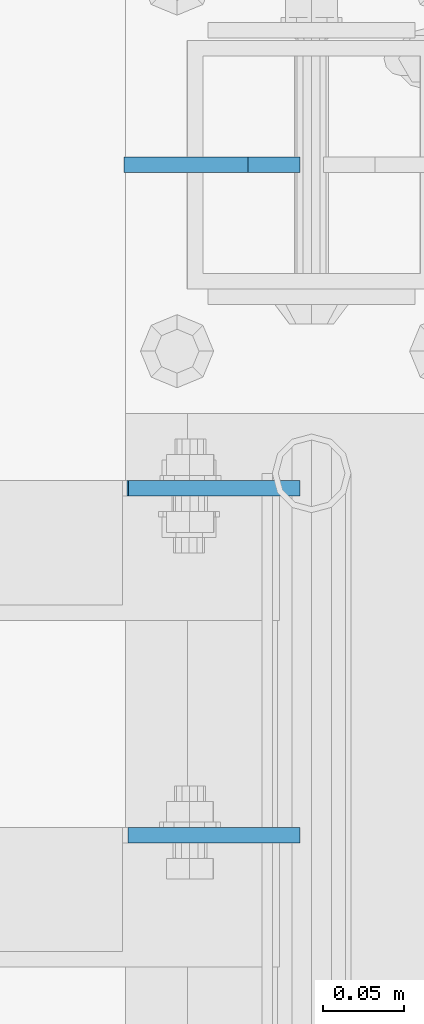
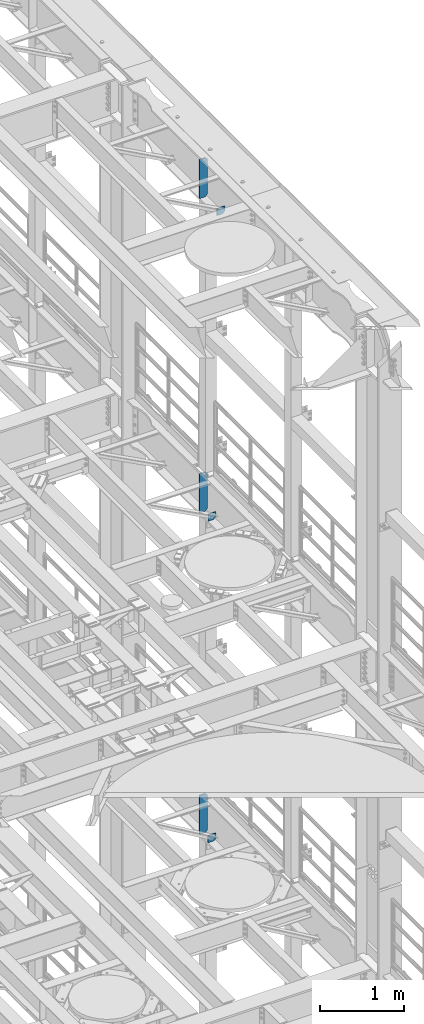
# One storey, part 1667 of 1876: 6 plates, 3 elements without a shape of their own.
"""IFC2X3 building model written with IfcOpenShell, lengths in millimetres."""

from ifc_helpers import new_model, si_unit, frame, origin_with_axes, place, context, subcontext, project, spatial, faceted_brep, material, type_object, element, aggregate, save


model = new_model("IFC2X3")

# Units and contexts
model_context = context("Model", 3, precision=1e-05, world=origin_with_axes())
body_context = subcontext(model_context, "Body", "Model", "MODEL_VIEW")
ifc_project = project(units=[si_unit("LENGTHUNIT", "METRE", prefix="MILLI"), si_unit("AREAUNIT", "SQUARE_METRE"), si_unit("VOLUMEUNIT", "CUBIC_METRE"), si_unit("MASSUNIT", "GRAM", prefix="KILO"), si_unit("TIMEUNIT", "SECOND"), si_unit("PLANEANGLEUNIT", "RADIAN"), si_unit("SOLIDANGLEUNIT", "STERADIAN"), si_unit("THERMODYNAMICTEMPERATUREUNIT", "DEGREE_CELSIUS"), si_unit("LUMINOUSINTENSITYUNIT", "LUMEN")], contexts=[model_context])

# Site, building, storey
site_placement = place(None, origin_with_axes())
site = spatial("IfcSite", under=ifc_project, at=site_placement, CompositionType="ELEMENT")
building_placement = place(site_placement, origin_with_axes())
building = spatial("IfcBuilding", under=site, at=building_placement, Name="Undefined", CompositionType="ELEMENT")
storey_placement = place(building_placement, origin_with_axes())
storey = spatial("IfcBuildingStorey", under=building, at=storey_placement, Name="Undefined", CompositionType="ELEMENT", Elevation=0.0)

# Assembly, plate
assembly_1_placement = place(storey_placement, origin_with_axes())
assembly_1 = element("IfcElementAssembly", 1, at=assembly_1_placement, inside=storey, Name="BEAM", AssemblyPlace="NOTDEFINED", PredefinedType="RIGID_FRAME")
ifc_material = material(Name="STEEL/A36")
plate_type_1 = type_object("IfcPlateType", PredefinedType="NOTDEFINED")
plate_1_placement = place(assembly_1_placement, frame((7612.85625000093, 5176.8375, 21958.3), z_axis=(0.0, 0.0, 1.0), x_axis=(-1.0, 0.0, 0.0)))
plate_1 = element("IfcPlate", 2, at=plate_1_placement, type_object=plate_type_1, material=ifc_material, Name="PLATE", context=body_context, shape_type="Brep", body=[
    faceted_brep([(-9.76996261670138e-14, -4.76250000000073, 31.75), (-3.4106151360902e-06, -4.76249999999982, 104.420860290527), (-3.4106151360902e-06, 4.76249999999982, 104.420860290527), (-9.76996261670138e-14, 4.76250000000073, 31.75), (105.552177429199, -4.76249999999982, 104.420860290527), (105.552177429199, 4.76249999999982, 104.420860290527), (105.552177429199, -4.76249999999982, 0.0), (105.552177429199, 4.76249999999982, 0.0), (31.75, -4.76250000000073, 0.0), (31.75, 4.76250000000073, 0.0)], [[[0, 1, 2, 3]], [[1, 4, 5, 2]], [[4, 6, 7, 5]], [[6, 8, 9, 7]], [[8, 0, 3, 9]], [[5, 7, 9, 3, 2]], [[8, 6, 4, 1, 0]]]),
])

assembly_2_placement = place(storey_placement, origin_with_axes())
assembly_2 = element("IfcElementAssembly", 3, at=assembly_2_placement, inside=storey, Name="BEAM", AssemblyPlace="NOTDEFINED", PredefinedType="RIGID_FRAME")
plate_type_2 = type_object("IfcPlateType", PredefinedType="NOTDEFINED")
plate_2_placement = place(assembly_2_placement, frame((7612.85625015191, 5389.56249999999, 12819.726415621), z_axis=(0.0, 0.0, -1.0), x_axis=(-1.0, 0.0, 0.0)))
plate_2 = element("IfcPlate", 4, at=plate_2_placement, type_object=plate_type_2, material=ifc_material, Name="PLATE", context=body_context, shape_type="Brep", body=[
    faceted_brep([(0.0, -4.76249999999982, 0.0), (-3.57139560946962e-06, -4.76249999999982, 81.6264114379865), (-3.57139560946962e-06, 4.76249999999982, 81.6264114379865), (0.0, 4.76249999999982, 0.0), (25.3999958038776, -4.76249999999982, 107.026412963854), (25.3999958038776, 4.76249999999982, 107.026412963854), (106.188095092818, -4.76249999999982, 107.02641296382), (106.188095092818, 4.76249999999982, 107.02641296382), (106.188095092773, -4.76249999999982, -7.27595761418343e-11), (106.188095092773, 4.76249999999982, -7.27595761418343e-11)], [[[0, 1, 2, 3]], [[1, 4, 5, 2]], [[4, 6, 7, 5]], [[6, 8, 9, 7]], [[8, 0, 3, 9]], [[5, 7, 9, 3, 2]], [[8, 6, 4, 1, 0]]]),
])

assembly_3_placement = place(storey_placement, origin_with_axes())
assembly_3 = element("IfcElementAssembly", 5, at=assembly_3_placement, inside=storey, Name="BEAM", AssemblyPlace="NOTDEFINED", PredefinedType="RIGID_FRAME")
plate_type_3 = type_object("IfcPlateType", PredefinedType="NOTDEFINED")
plate_3_placement = place(assembly_3_placement, frame((7612.85625000072, 5389.5625, 17386.2999999996), z_axis=(-1.0, 0.0, 0.0), x_axis=(0.0, 0.0, 1.0)))
plate_3 = element("IfcPlate", 6, at=plate_3_placement, type_object=plate_type_3, material=ifc_material, Name="PLATE", context=body_context, shape_type="Brep", body=[
    faceted_brep([(-9.76996261670138e-14, -4.76250000000073, 31.75), (0.0, -4.76249999999982, 105.281791687012), (0.0, 4.76249999999982, 105.281791687012), (-9.76996261670138e-14, 4.76250000000073, 31.75), (103.391876220703, -4.76249999999982, 105.281791687012), (103.391876220703, 4.76249999999982, 105.281791687012), (103.391876220703, -4.76249999999982, 0.0), (103.391876220703, 4.76249999999982, 0.0), (31.75, -4.76250000000073, 0.0), (31.75, 4.76250000000073, 0.0)], [[[0, 1, 2, 3]], [[1, 4, 5, 2]], [[4, 6, 7, 5]], [[6, 8, 9, 7]], [[8, 0, 3, 9]], [[5, 7, 9, 3, 2]], [[8, 6, 4, 1, 0]]]),
])

# Plate
plate_type_4 = type_object("IfcPlateType", PredefinedType="NOTDEFINED")
plate_4_placement = place(assembly_1_placement, frame((7612.85625, 5588.0, 21958.3), z_axis=(0.0, 0.0, 1.0), x_axis=(-1.0, 0.0, 0.0)))
plate_4 = element("IfcPlate", 7, at=plate_4_placement, type_object=plate_type_4, material=ifc_material, Name="PLATE", context=body_context, shape_type="Brep", body=[
    faceted_brep([(-9.76996261670138e-14, -4.76250000000073, 31.75), (0.0, -4.76249999999982, 539.75), (0.0, 4.76249999999982, 539.75), (-9.76996261670138e-14, 4.76250000000073, 31.75), (31.75, -4.76249999999982, 571.5), (31.75, 4.76249999999982, 571.5), (107.949996948242, -4.76249999999982, 571.5), (107.949996948242, 4.76249999999982, 571.5), (107.950006484985, -4.76250000000073, 0.0), (107.950006484985, 4.76250000000073, 0.0), (31.75, -4.76250000000073, 0.0), (31.75, 4.76250000000073, 0.0)], [[[0, 1, 2, 3]], [[1, 4, 5, 2]], [[4, 6, 7, 5]], [[6, 8, 9, 7]], [[8, 10, 11, 9]], [[10, 0, 3, 11]], [[5, 7, 9, 11, 3, 2]], [[10, 8, 6, 4, 1, 0]]]),
])

aggregate(assembly_1, [plate_1, plate_4])

plate_5_placement = place(assembly_3_placement, frame((7612.85625, 5588.0, 17386.3), z_axis=(0.0, 0.0, 1.0), x_axis=(-1.0, 0.0, 0.0)))
plate_5 = element("IfcPlate", 8, at=plate_5_placement, type_object=plate_type_4, material=ifc_material, Name="PLATE", context=body_context, shape_type="Brep", body=[
    faceted_brep([(-9.76996261670138e-14, -4.76250000000073, 31.75), (0.0, -4.76249999999982, 539.75), (0.0, 4.76249999999982, 539.75), (-9.76996261670138e-14, 4.76250000000073, 31.75), (31.75, -4.76249999999982, 571.5), (31.75, 4.76249999999982, 571.5), (107.949996948242, -4.76249999999982, 571.5), (107.949996948242, 4.76249999999982, 571.5), (107.950006484985, -4.76250000000073, 0.0), (107.950006484985, 4.76250000000073, 0.0), (31.75, -4.76250000000073, 0.0), (31.75, 4.76250000000073, 0.0)], [[[0, 1, 2, 3]], [[1, 4, 5, 2]], [[4, 6, 7, 5]], [[6, 8, 9, 7]], [[8, 10, 11, 9]], [[10, 0, 3, 11]], [[5, 7, 9, 11, 3, 2]], [[10, 8, 6, 4, 1, 0]]]),
])

aggregate(assembly_3, [plate_3, plate_5])

plate_6_placement = place(assembly_2_placement, frame((7612.85625, 5588.0, 12712.7), z_axis=(0.0, 0.0, 1.0), x_axis=(-1.0, 0.0, 0.0)))
plate_6 = element("IfcPlate", 9, at=plate_6_placement, type_object=plate_type_4, material=ifc_material, Name="PLATE", context=body_context, shape_type="Brep", body=[
    faceted_brep([(-9.76996261670138e-14, -4.76250000000073, 31.75), (0.0, -4.76249999999982, 539.75), (0.0, 4.76249999999982, 539.75), (-9.76996261670138e-14, 4.76250000000073, 31.75), (31.75, -4.76249999999982, 571.5), (31.75, 4.76249999999982, 571.5), (107.949996948242, -4.76249999999982, 571.5), (107.949996948242, 4.76249999999982, 571.5), (107.950006484985, -4.76250000000073, 0.0), (107.950006484985, 4.76250000000073, 0.0), (31.75, -4.76250000000073, 0.0), (31.75, 4.76250000000073, 0.0)], [[[0, 1, 2, 3]], [[1, 4, 5, 2]], [[4, 6, 7, 5]], [[6, 8, 9, 7]], [[8, 10, 11, 9]], [[10, 0, 3, 11]], [[5, 7, 9, 11, 3, 2]], [[10, 8, 6, 4, 1, 0]]]),
])

aggregate(assembly_2, [plate_2, plate_6])

save(model, "model.ifc")
